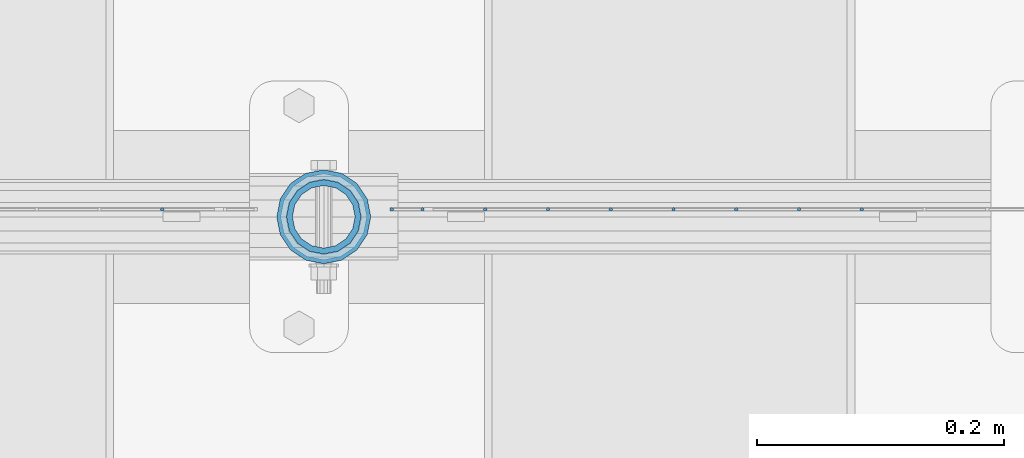
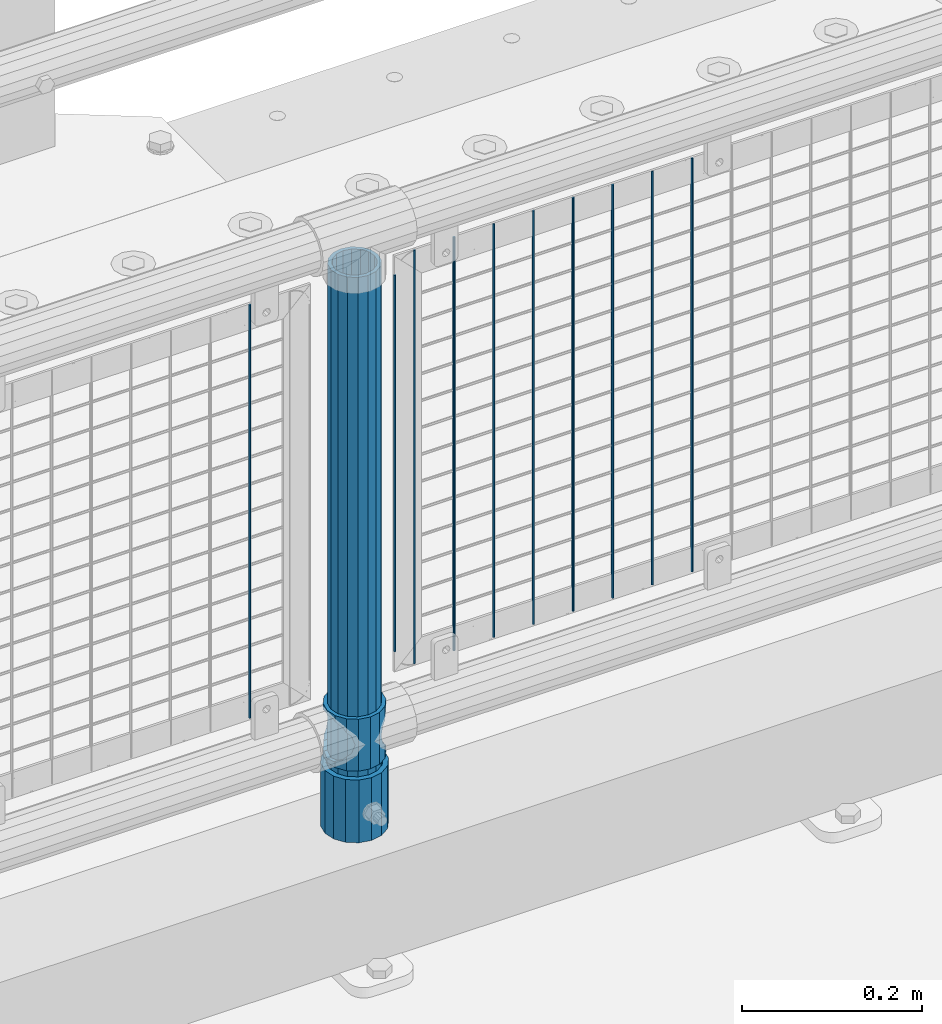
# One storey, part 77 of 270: 13 columns.
"""IFC2X3 building model written with IfcOpenShell, lengths in millimetres."""

import ifcopenshell
import ifcopenshell.guid

model = None  # the IFC model being written
_history = None  # IfcOwnerHistory: only IFC2X3 demands one
_inside = {}  # id of a spatial element -> (the spatial element, [elements in it])
_under = {}  # id of a project, library or spatial element -> (it, [spatial elements below it])
_declared = {}  # id of a project -> (the project, [libraries it declares])
_typed = {}  # id of a type object -> (the type object, [elements of that type])
_made_of = {}  # id of a material, layer set ... -> (it, [elements and type objects made of it])


def new_model(schema):
    """Start an empty IFC model of exactly this schema.

    Asked for "IFC4X3", IfcOpenShell would pick the latest addendum, in which some entities
    have other attributes; the version numbers below select the first issue.
    IFC2X3 requires an IfcOwnerHistory on every rooted entity: one is made here for all.
    """
    global model, _history
    if schema == "IFC4X3":
        model = ifcopenshell.file(schema_version=(4, 3, 0, 0))
    else:
        model = ifcopenshell.file(schema=schema)
    _inside.clear()
    _under.clear()
    _declared.clear()
    _typed.clear()
    _made_of.clear()
    _history = None
    if model.schema == "IFC2X3":
        org = make("IfcOrganization", Name="unknown")
        user = make(
            "IfcPersonAndOrganization",
            ThePerson=make("IfcPerson", FamilyName="unknown"),
            TheOrganization=org,
        )
        app = make(
            "IfcApplication",
            ApplicationDeveloper=org,
            Version="unknown",
            ApplicationFullName="unknown",
            ApplicationIdentifier="unknown",
        )
        _history = make(
            "IfcOwnerHistory",
            OwningUser=user,
            OwningApplication=app,
            ChangeAction="ADDED",
            CreationDate=0,
        )
    return model


def make(cls, **values):
    """One entity of the class cls with the attributes given. An attribute that is None is left unset."""
    return model.create_entity(
        cls, **{name: value for name, value in values.items() if value is not None}
    )


def rooted(cls, **values):
    """An entity with a GlobalId (a new one), such as an element, a storey or a relation."""
    return make(cls, GlobalId=ifcopenshell.guid.new(), OwnerHistory=_history, **values)


def si_unit(unit_type, name, prefix=None):
    """IfcSIUnit, for example si_unit("LENGTHUNIT", "METRE", prefix="MILLI")."""
    return make("IfcSIUnit", UnitType=unit_type, Prefix=prefix, Name=name)


def assignment(units):
    """IfcUnitAssignment: the units of a project."""
    return None if units is None else make("IfcUnitAssignment", Units=units)


def point(xyz):
    """IfcCartesianPoint."""
    return None if xyz is None else make("IfcCartesianPoint", Coordinates=xyz)


def direction(xyz):
    """IfcDirection."""
    return None if xyz is None else make("IfcDirection", DirectionRatios=xyz)


def frame(location, z_axis=None, x_axis=None):
    """IfcAxis2Placement3D, a coordinate frame: its origin and axes. An axis left out is left unset."""
    return make(
        "IfcAxis2Placement3D",
        Location=point(location),
        Axis=direction(z_axis),
        RefDirection=direction(x_axis),
    )


def origin_with_axes():
    """The frame at (0, 0, 0) with the z axis (0, 0, 1) and the x axis (1, 0, 0) written out."""
    return frame((0.0, 0.0, 0.0), z_axis=(0.0, 0.0, 1.0), x_axis=(1.0, 0.0, 0.0))


def place(relative_to, where):
    """IfcLocalPlacement: puts the frame where relative to a parent placement (None: the world)."""
    return make(
        "IfcLocalPlacement", PlacementRelTo=relative_to, RelativePlacement=where
    )


def context(
    kind, dimensions, precision=None, world=None, true_north=None, identifier=None
):
    """IfcGeometricRepresentationContext, for example the 3D "Model" context."""
    return make(
        "IfcGeometricRepresentationContext",
        ContextIdentifier=identifier,
        ContextType=kind,
        CoordinateSpaceDimension=dimensions,
        Precision=precision,
        WorldCoordinateSystem=world,
        TrueNorth=true_north,
    )


def subcontext(parent, identifier, kind, view, scale=None):
    """IfcGeometricRepresentationSubContext, for example "Body" below "Model"."""
    return make(
        "IfcGeometricRepresentationSubContext",
        ContextIdentifier=identifier,
        ContextType=kind,
        ParentContext=parent,
        TargetScale=scale,
        TargetView=view,
    )


def project(units=None, contexts=None):
    """IfcProject with its units and contexts."""
    return rooted(
        "IfcProject",
        Name="project",
        RepresentationContexts=contexts,
        UnitsInContext=assignment(units),
    )


def spatial(cls, under=None, at=None, **own):
    """A site, building, storey or space (cls), placed at a placement, below another one or the project."""
    s = rooted(cls, ObjectPlacement=at, **own)
    if under is not None:
        _under.setdefault(under.id(), (under, []))[1].append(s)
    return s


def faces_of(points, faces, orient=None, outer=None):
    """IfcFace entities. A face is a list of loops; a loop is a list of indices into points, from 0.

    orient and outer hold one flag for each loop. By default every Orientation is true, the
    first loop of a face is its IfcFaceOuterBound and the others are IfcFaceBound.
    """
    made = []
    for i, loops in enumerate(faces):
        bounds = []
        for j, loop in enumerate(loops):
            is_outer = j == 0 if outer is None else outer[i][j]
            bounds.append(
                make(
                    "IfcFaceOuterBound" if is_outer else "IfcFaceBound",
                    Bound=make("IfcPolyLoop", Polygon=[points[k] for k in loop]),
                    Orientation=True if orient is None else orient[i][j],
                )
            )
        made.append(make("IfcFace", Bounds=bounds))
    return made


def faceted_brep(points, faces, orient=None, outer=None, voids=None):
    """IfcFacetedBrep: a solid bounded by flat faces; with voids (closed shells), ...WithVoids."""
    shared = [point(p) for p in points]
    hull = make("IfcClosedShell", CfsFaces=faces_of(shared, faces, orient, outer))
    if voids is None:
        return make("IfcFacetedBrep", Outer=hull)
    return make(
        "IfcFacetedBrepWithVoids",
        Outer=hull,
        Voids=[
            make(cls, CfsFaces=faces_of(shared, fs, o, b)) for cls, fs, o, b in voids
        ],
    )


def shape(context_of_items, identifier, shape_type, items):
    """IfcShapeRepresentation: the items that make up one representation, for example the "Body"."""
    return make(
        "IfcShapeRepresentation",
        ContextOfItems=context_of_items,
        RepresentationIdentifier=identifier,
        RepresentationType=shape_type,
        Items=items,
    )


def material(Name=None, Category=None):
    """IfcMaterial."""
    return make("IfcMaterial", Name=Name, Category=Category)


def made_of(thing, what):
    """Note that an element or type object is made of a material, layer set ...; save() writes the relation."""
    if what is not None:
        _made_of.setdefault(what.id(), (what, []))[1].append(thing)
    return thing


def type_object(cls, material=None, **own):
    """A type object (cls), such as IfcWallType, which elements share."""
    return made_of(rooted(cls, **own), material)


def element(
    cls,
    number,
    at=None,
    inside=None,
    cuts=None,
    type_object=None,
    material=None,
    context=None,
    identifier="Body",
    shape_type=None,
    held_by="IfcProductDefinitionShape",
    body=None,
    shapes=None,
    **own,
):
    """One element of the class cls, such as IfcWall. Its Tag is "e" and its number.

    at: its placement. inside: the storey or other place that contains it. cuts: it is an
    opening in that element (IfcRelVoidsElement). A single representation is given by context,
    identifier, shape_type and body (its items); several are given by shapes. held_by: the class
    of the entity that holds the representations. save() writes the other relations.
    """
    e = rooted(cls, Tag="e%d" % number, ObjectPlacement=at, **own)
    if body is not None:
        shapes = [shape(context, identifier, shape_type, body)]
    if shapes is not None:
        e.Representation = make(held_by, Representations=shapes)
    if inside is not None:
        _inside.setdefault(inside.id(), (inside, []))[1].append(e)
    if cuts is not None:
        rooted(
            "IfcRelVoidsElement", RelatingBuildingElement=cuts, RelatedOpeningElement=e
        )
    if type_object is not None:
        _typed.setdefault(type_object.id(), (type_object, []))[1].append(e)
    return made_of(e, material)


def aggregate(whole, parts):
    """IfcRelAggregates: a whole, such as a stair, and the parts it consists of."""
    return rooted("IfcRelAggregates", RelatingObject=whole, RelatedObjects=parts)


def save(model, path):
    """Write the relations noted so far, then the file.

    IfcRelAggregates (storeys below a building ...), IfcRelContainedInSpatialStructure (elements
    in a storey), IfcRelDefinesByType, IfcRelAssociatesMaterial and IfcRelDeclares: one each for
    every whole, place, type object, material and project.
    """
    for whole, parts in _under.values():
        aggregate(whole, parts)
    for where, things in _inside.values():
        rooted(
            "IfcRelContainedInSpatialStructure",
            RelatedElements=things,
            RelatingStructure=where,
        )
    for kind, things in _typed.values():
        rooted("IfcRelDefinesByType", RelatedObjects=things, RelatingType=kind)
    for what, things in _made_of.values():
        rooted("IfcRelAssociatesMaterial", RelatedObjects=things, RelatingMaterial=what)
    for by, libraries in _declared.values():
        rooted("IfcRelDeclares", RelatingContext=by, RelatedDefinitions=libraries)
    model.write(path)


model = new_model("IFC2X3")

# Units and contexts
model_context = context("Model", 3, precision=1e-05, world=origin_with_axes())
body_context = subcontext(model_context, "Body", "Model", "MODEL_VIEW")
ifc_project = project(units=[si_unit("LENGTHUNIT", "METRE", prefix="MILLI"), si_unit("AREAUNIT", "SQUARE_METRE"), si_unit("VOLUMEUNIT", "CUBIC_METRE"), si_unit("MASSUNIT", "GRAM", prefix="KILO"), si_unit("TIMEUNIT", "SECOND"), si_unit("PLANEANGLEUNIT", "RADIAN"), si_unit("SOLIDANGLEUNIT", "STERADIAN"), si_unit("THERMODYNAMICTEMPERATUREUNIT", "DEGREE_CELSIUS"), si_unit("LUMINOUSINTENSITYUNIT", "LUMEN")], contexts=[model_context])

# Site, building, storey
site_placement = place(None, origin_with_axes())
site = spatial("IfcSite", under=ifc_project, at=site_placement, CompositionType="ELEMENT")
building_placement = place(site_placement, origin_with_axes())
building = spatial("IfcBuilding", under=site, at=building_placement, Name="Standard", CompositionType="ELEMENT")
storey_placement = place(building_placement, origin_with_axes())
storey = spatial("IfcBuildingStorey", under=building, at=storey_placement, Name="Undefined", CompositionType="ELEMENT", Elevation=0.0)

# Columns
ifc_material_1 = material()
column_type_1 = type_object("IfcColumnType", PredefinedType="NOTDEFINED")
column_1_placement = place(storey_placement, frame((5520.0, -16335.5, 168.02), z_axis=(-1.0, 0.0, 0.0), x_axis=(0.0, 0.0, 1.0)))
element("IfcColumn", 1, at=column_1_placement, inside=storey, type_object=column_type_1, material=ifc_material_1, context=body_context, shape_type="Brep", body=[
    faceted_brep([(0.0, -25.3500000000004, 0.0), (0.0, -23.4203461491616, 9.70102501045403), (760.0, -23.4203461491616, 9.70102501045403), (760.0, -25.3500000000004, 0.0), (0.0, -17.9251569030785, 17.9251569030785), (760.0, -17.9251569030785, 17.9251569030785), (0.0, -9.70102501045585, 23.4203461491597), (760.0, -9.70102501045585, 23.4203461491597), (0.0, 0.0, 25.3499999999985), (760.0, 0.0, 25.3499999999985), (0.0, 9.70102501045585, 23.4203461491597), (760.0, 9.70102501045585, 23.4203461491597), (0.0, 17.9251569030785, 17.9251569030785), (760.0, 17.9251569030785, 17.9251569030785), (0.0, 23.4203461491616, 9.70102501045403), (760.0, 23.4203461491616, 9.70102501045403), (0.0, 25.3500000000004, 0.0), (760.0, 25.3500000000004, 0.0), (0.0, 23.4203461491616, -9.70102501045403), (760.0, 23.4203461491616, -9.70102501045403), (0.0, 17.9251569030785, -17.9251569030785), (760.0, 17.9251569030785, -17.9251569030785), (0.0, 9.70102501045585, -23.4203461491597), (760.0, 9.70102501045585, -23.4203461491597), (0.0, 0.0, -25.3499999999985), (760.0, 0.0, -25.3499999999985), (0.0, -9.70102501045585, -23.4203461491597), (760.0, -9.70102501045585, -23.4203461491597), (0.0, -17.9251569030785, -17.9251569030785), (760.0, -17.9251569030785, -17.9251569030785), (0.0, -23.4203461491616, -9.70102501045403), (760.0, -23.4203461491616, -9.70102501045403), (0.0, -30.1499999999996, 0.0), (0.0, -27.8549679052157, -11.5379054858058), (760.0, -27.8549679052157, -11.5379054858058), (760.0, -30.1499999999996, 0.0), (0.0, -21.3192694527752, -21.3192694527752), (760.0, -21.3192694527752, -21.3192694527752), (0.0, -11.5379054858076, -27.8549679052157), (760.0, -11.5379054858076, -27.8549679052157), (0.0, 0.0, -30.1500000000015), (760.0, 0.0, -30.1500000000015), (0.0, 11.5379054858076, -27.8549679052157), (760.0, 11.5379054858076, -27.8549679052157), (0.0, 21.3192694527752, -21.3192694527752), (760.0, 21.3192694527752, -21.3192694527752), (0.0, 27.8549679052157, -11.5379054858058), (760.0, 27.8549679052157, -11.5379054858058), (0.0, 30.1499999999996, 0.0), (760.0, 30.1499999999996, 0.0), (0.0, 27.8549679052157, 11.5379054858058), (760.0, 27.8549679052157, 11.5379054858058), (0.0, 21.3192694527752, 21.3192694527752), (760.0, 21.3192694527752, 21.3192694527752), (0.0, 11.5379054858076, 27.8549679052157), (760.0, 11.5379054858076, 27.8549679052157), (0.0, 0.0, 30.1500000000015), (760.0, 0.0, 30.1500000000015), (0.0, -11.5379054858076, 27.8549679052157), (760.0, -11.5379054858076, 27.8549679052157), (0.0, -21.3192694527752, 21.3192694527752), (760.0, -21.3192694527752, 21.3192694527752), (0.0, -27.8549679052157, 11.5379054858058), (760.0, -27.8549679052157, 11.5379054858058)], [[[0, 1, 2, 3]], [[1, 4, 5, 2]], [[4, 6, 7, 5]], [[6, 8, 9, 7]], [[8, 10, 11, 9]], [[10, 12, 13, 11]], [[12, 14, 15, 13]], [[14, 16, 17, 15]], [[16, 18, 19, 17]], [[18, 20, 21, 19]], [[20, 22, 23, 21]], [[22, 24, 25, 23]], [[24, 26, 27, 25]], [[26, 28, 29, 27]], [[28, 30, 31, 29]], [[30, 0, 3, 31]], [[32, 33, 34, 35]], [[33, 36, 37, 34]], [[36, 38, 39, 37]], [[38, 40, 41, 39]], [[40, 42, 43, 41]], [[42, 44, 45, 43]], [[44, 46, 47, 45]], [[46, 48, 49, 47]], [[48, 50, 51, 49]], [[50, 52, 53, 51]], [[52, 54, 55, 53]], [[54, 56, 57, 55]], [[56, 58, 59, 57]], [[58, 60, 61, 59]], [[60, 62, 63, 61]], [[62, 32, 35, 63]], [[37, 39, 41, 43, 45, 47, 49, 51, 53, 55, 57, 59, 61, 63, 35, 34], [5, 7, 9, 11, 13, 15, 17, 19, 21, 23, 25, 27, 29, 31, 3, 2]], [[62, 60, 58, 56, 54, 52, 50, 48, 46, 44, 42, 40, 38, 36, 33, 32], [30, 28, 26, 24, 22, 20, 18, 16, 14, 12, 10, 8, 6, 4, 1, 0]]]),
])
column_type_2 = type_object("IfcColumnType", PredefinedType="NOTDEFINED")
column_2_placement = place(storey_placement, frame((5520.0, -16335.5, 168.02), z_axis=(0.0, 1.0, 0.0), x_axis=(0.0, 0.0, 1.0)))
element("IfcColumn", 2, at=column_2_placement, inside=storey, type_object=column_type_2, material=ifc_material_1, context=body_context, shape_type="Brep", body=[
    faceted_brep([(0.0, -31.75, 0.0), (0.0, -29.3331751572332, 12.1501989775916), (85.0, -29.3331751572332, 12.1501989775916), (85.0, -31.75, 0.0), (0.0, -22.4506403026717, 22.4506403026735), (85.0, -22.4506403026717, 22.4506403026735), (0.0, -12.1501989775934, 29.3331751572332), (85.0, -12.1501989775934, 29.3331751572332), (0.0, 0.0, 31.75), (85.0, 0.0, 31.75), (0.0, 12.1501989775934, 29.3331751572332), (85.0, 12.1501989775934, 29.3331751572332), (0.0, 22.4506403026717, 22.4506403026735), (85.0, 22.4506403026717, 22.4506403026735), (0.0, 29.3331751572332, 12.1501989775916), (85.0, 29.3331751572332, 12.1501989775916), (0.0, 31.75, 0.0), (85.0, 31.75, 0.0), (0.0, 29.3331751572332, -12.1501989775916), (85.0, 29.3331751572332, -12.1501989775916), (0.0, 22.4506403026717, -22.4506403026735), (85.0, 22.4506403026717, -22.4506403026735), (0.0, 12.1501989775934, -29.3331751572332), (85.0, 12.1501989775934, -29.3331751572332), (0.0, 0.0, -31.75), (85.0, 0.0, -31.75), (0.0, -12.1501989775934, -29.3331751572332), (85.0, -12.1501989775934, -29.3331751572332), (0.0, -22.4506403026717, -22.4506403026735), (85.0, -22.4506403026717, -22.4506403026735), (0.0, -29.3331751572332, -12.1501989775916), (85.0, -29.3331751572332, -12.1501989775916), (0.0, -38.0499999999993, 0.0), (0.0, -35.1536162120537, -14.561104601491), (85.0, -35.1536162120537, -14.561104601491), (85.0, -38.0499999999993, 0.0), (0.0, -26.9054130241493, -26.9054130241475), (85.0, -26.9054130241493, -26.9054130241475), (0.0, -14.5611046014928, -35.1536162120537), (85.0, -14.5611046014928, -35.1536162120537), (0.0, 0.0, -38.0499999999993), (85.0, 0.0, -38.0499999999993), (0.0, 14.5611046014928, -35.1536162120537), (85.0, 14.5611046014928, -35.1536162120537), (0.0, 26.9054130241493, -26.9054130241475), (85.0, 26.9054130241493, -26.9054130241475), (0.0, 35.1536162120537, -14.561104601491), (85.0, 35.1536162120537, -14.561104601491), (0.0, 38.0499999999993, 0.0), (85.0, 38.0499999999993, 0.0), (0.0, 35.1536162120537, 14.561104601491), (85.0, 35.1536162120537, 14.561104601491), (0.0, 26.9054130241493, 26.9054130241475), (85.0, 26.9054130241493, 26.9054130241475), (0.0, 14.5611046014928, 35.1536162120537), (85.0, 14.5611046014928, 35.1536162120537), (0.0, 0.0, 38.0499999999993), (85.0, 0.0, 38.0499999999993), (0.0, -14.5611046014928, 35.1536162120537), (85.0, -14.5611046014928, 35.1536162120537), (0.0, -26.9054130241493, 26.9054130241475), (85.0, -26.9054130241493, 26.9054130241475), (0.0, -35.1536162120537, 14.561104601491), (85.0, -35.1536162120537, 14.561104601491)], [[[0, 1, 2, 3]], [[1, 4, 5, 2]], [[4, 6, 7, 5]], [[6, 8, 9, 7]], [[8, 10, 11, 9]], [[10, 12, 13, 11]], [[12, 14, 15, 13]], [[14, 16, 17, 15]], [[16, 18, 19, 17]], [[18, 20, 21, 19]], [[20, 22, 23, 21]], [[22, 24, 25, 23]], [[24, 26, 27, 25]], [[26, 28, 29, 27]], [[28, 30, 31, 29]], [[30, 0, 3, 31]], [[32, 33, 34, 35]], [[33, 36, 37, 34]], [[36, 38, 39, 37]], [[38, 40, 41, 39]], [[40, 42, 43, 41]], [[42, 44, 45, 43]], [[44, 46, 47, 45]], [[46, 48, 49, 47]], [[48, 50, 51, 49]], [[50, 52, 53, 51]], [[52, 54, 55, 53]], [[54, 56, 57, 55]], [[56, 58, 59, 57]], [[58, 60, 61, 59]], [[60, 62, 63, 61]], [[62, 32, 35, 63]], [[37, 39, 41, 43, 45, 47, 49, 51, 53, 55, 57, 59, 61, 63, 35, 34], [5, 7, 9, 11, 13, 15, 17, 19, 21, 23, 25, 27, 29, 31, 3, 2]], [[62, 60, 58, 56, 54, 52, 50, 48, 46, 44, 42, 40, 38, 36, 33, 32], [30, 28, 26, 24, 22, 20, 18, 16, 14, 12, 10, 8, 6, 4, 1, 0]]]),
])
ifc_material_2 = material(Name="Misc_Undefined")
column_type_3 = type_object("IfcColumnType", PredefinedType="NOTDEFINED")
column_3_placement = place(storey_placement, frame((5520.0, -16335.5, 263.02), z_axis=(-1.0, 0.0, 0.0), x_axis=(0.0, 0.0, 1.0)))
element("IfcColumn", 3, at=column_3_placement, inside=storey, type_object=column_type_3, material=ifc_material_2, context=body_context, shape_type="Brep", body=[
    faceted_brep([(63.1897438117183, 11.6144421722802, -32.8397438117208), (63.1897438117183, 11.6144421722802, -28.0397438117179), (56.6106908090125, 21.4606908090118, -21.46069080901), (56.6106908090125, 21.4606908090118, -27.1226768591005), (61.9623795176767, 13.4513226476338, -32.4743655677703), (46.7644421722812, 28.0397438117179, -11.614442172282), (46.7644421722812, 28.0397438117179, -20.0882031229812), (51.5310424080071, 24.8548033587067, -24.8548033587067), (35.1500000000015, 30.35, 0.0), (35.1500000000008, 30.3500000000004, -16.6306603983612), (23.5355578277203, 28.0397438117179, -11.614442172282), (23.5355578277203, 28.0397438117179, -20.0882031229812), (18.7689575919954, 24.8548033587067, -24.8548033587067), (13.689309190989, 21.4606908090118, -21.46069080901), (13.689309190989, 21.4606908090118, -27.1226768591005), (8.33762048232484, 13.4513226476338, -32.4743655677703), (7.11025618828324, 11.6144421722802, -28.0397438117179), (7.11025618828324, 11.6144421722802, -32.8397438117208), (4.80000000000075, 0.0, -30.3499999999985), (4.80000000000075, 0.0, -35.1500000000015), (7.11025618828319, -11.6144421722802, -28.0397438117179), (7.11025618828319, -11.6144421722802, -32.8397438117172), (13.689309190989, -21.4606908090118, -21.46069080901), (13.689309190989, -21.4606908090118, -27.1226768591041), (8.33762048232484, -13.4513226476338, -32.4743655677703), (23.5355578277203, -28.0397438117179, -11.614442172282), (23.5355578277203, -28.0397438117179, -20.0882031229885), (18.7689575919954, -24.8548033587067, -24.8548033587067), (35.1500000000015, -30.35, 0.0), (35.1500000000008, -30.3500000000004, -16.6306603983721), (46.7644421722812, -28.0397438117179, -11.614442172282), (46.7644421722812, -28.0397438117179, -20.0882031229885), (51.5310424080071, -24.8548033587067, -24.8548033587067), (56.6106908090125, -21.4606908090118, -21.46069080901), (56.6106908090125, -21.4606908090118, -27.1226768591041), (61.9623795176767, -13.4513226476338, -32.4743655677703), (63.1897438117183, -11.6144421722802, -28.0397438117179), (63.1897438117183, -11.6144421722802, -32.8397438117172), (65.5000000000008, 0.0, -30.3499999999985), (65.5000000000008, 0.0, -35.1500000000015), (0.0, -28.0397438117179, -11.614442172282), (0.0, -30.3500000000004, 0.0), (0.0, -21.4606908090118, -21.46069080901), (0.0, -11.6144421722802, -28.0397438117179), (0.0, 0.0, -30.3499999999985), (0.0, 11.6144421722802, -28.0397438117179), (0.0, 21.4606908090118, -21.46069080901), (0.0, 28.0397438117179, -11.614442172282), (0.0, 30.3500000000004, 0.0), (0.0, 28.0397438117179, 11.614442172282), (23.5355578277192, 28.0397438117179, 11.614442172282), (0.0, 21.4606908090118, 21.46069080901), (13.6893091909879, 21.4606908090118, 21.46069080901), (0.0, 11.6144421722802, 28.0397438117179), (7.11025618828211, 11.6144421722802, 28.0397438117179), (0.0, 0.0, 30.3499999999985), (4.79999999999961, 0.0, 30.3499999999985), (0.0, -11.6144421722802, 28.0397438117179), (7.11025618828205, -11.6144421722802, 28.0397438117179), (0.0, -21.4606908090118, 21.46069080901), (13.6893091909879, -21.4606908090118, 21.46069080901), (0.0, -28.0397438117179, 11.614442172282), (23.5355578277191, -28.0397438117179, 11.614442172282), (0.0, -32.4743655677721, 13.4513226476338), (0.0, -35.1499999999996, 0.0), (70.2999999999993, -35.1499999999996, 0.0), (70.2999999999993, -32.4743655677721, 13.4513226476338), (0.0, 13.4513226476338, -32.4743655677703), (0.0, 24.8548033587067, -24.8548033587067), (0.0, 0.0, -35.1499999999996), (0.0, -13.4513226476338, -32.4743655677703), (0.0, -24.8548033587067, -24.8548033587067), (0.0, -24.8548033587067, 24.8548033587067), (0.0, -13.4513226476338, 32.4743655677703), (0.0, 0.0, 35.1499999999996), (0.0, 13.4513226476338, 32.4743655677703), (0.0, 24.8548033587067, 24.8548033587067), (0.0, 32.4743655677721, 13.4513226476338), (0.0, 35.1499999999996, 0.0), (0.0, 32.4743655677721, -13.4513226476338), (0.0, -32.4743655677721, -13.4513226476338), (70.2999999999993, 32.4743655677721, 13.4513226476338), (70.2999999999993, 35.1499999999996, 0.0), (70.2999999999993, 32.4743655677721, -13.4513226476338), (70.2999999999993, 24.8548033587067, -24.8548033587067), (70.2999999999993, 13.4513226476338, -32.4743655677703), (70.2999999999993, 0.0, -35.1500000000015), (70.2999999999993, -13.4513226476338, -32.4743655677703), (70.2999999999993, -24.8548033587067, -24.8548033587067), (70.2999999999993, -32.4743655677721, -13.4513226476338), (70.2999999999993, 28.0397438117179, 11.614442172282), (70.2999999999993, 21.4606908090118, 21.46069080901), (56.6106908090114, 21.4606908090118, 21.46069080901), (46.7644421722801, 28.0397438117179, 11.614442172282), (70.2999999999993, 11.6144421722802, 28.0397438117179), (63.1897438117172, 11.6144421722802, 28.0397438117179), (70.2999999999993, 0.0, 30.3499999999985), (65.4999999999997, 0.0, 30.3499999999985), (70.2999999999993, -11.6144421722802, 28.0397438117179), (63.1897438117172, -11.6144421722802, 28.0397438117179), (70.2999999999993, -21.4606908090118, 21.46069080901), (56.6106908090114, -21.4606908090118, 21.46069080901), (70.2999999999993, -28.0397438117179, 11.614442172282), (46.7644421722801, -28.0397438117179, 11.614442172282), (70.2999999999993, -11.6144421722802, -28.0397438117179), (70.2999999999993, 0.0, -30.3499999999985), (70.2999999999993, -21.4606908090118, -21.46069080901), (70.2999999999993, -28.0397438117179, -11.614442172282), (70.2999999999993, -30.3500000000004, 0.0), (70.2999999999993, 24.8548033587067, 24.8548033587067), (70.2999999999993, 13.4513226476338, 32.4743655677703), (70.2999999999993, 0.0, 35.1500000000015), (70.2999999999993, -13.4513226476338, 32.4743655677703), (70.2999999999993, -24.8548033587067, 24.8548033587067), (70.2999999999993, 30.3500000000004, 0.0), (70.2999999999993, 28.0397438117179, -11.614442172282), (70.2999999999993, 21.4606908090118, -21.46069080901), (70.2999999999993, 11.6144421722802, -28.0397438117179), (61.9623795176767, 13.4513226476338, 32.4743655677703), (51.5310424080039, 24.8548033587067, 24.8548033587067), (56.6106908090114, 21.4606908090118, 27.1226768591041), (65.4999999999997, 0.0, 35.1500000000015), (63.1897438117172, 11.6144421722802, 32.8397438117172), (63.1897438117172, -11.6144421722802, 32.8397438117172), (61.9623795176767, -13.4513226476338, 32.4743655677703), (56.6106908090114, -21.4606908090118, 27.1226768591077), (51.5310424080071, -24.8548033587067, 24.8548033587067), (18.7689575919954, -24.8548033587067, 24.8548033587067), (46.7644421722801, -28.0397438117179, 20.0882031229849), (35.1499999999996, -30.3500000000004, 16.6306603983649), (23.5355578277191, -28.0397438117179, 20.0882031229849), (8.33762048232262, -13.4513226476338, 32.4743655677703), (13.6893091909879, -21.4606908090118, 27.1226768591077), (4.79999999999961, 0.0, 35.1500000000015), (7.11025618828205, -11.6144421722802, 32.8397438117172), (7.11025618828211, 11.6144421722802, 32.8397438117172), (8.33762048232262, 13.4513226476338, 32.4743655677703), (13.6893091909879, 21.4606908090118, 27.1226768591041), (18.7689575919954, 24.8548033587067, 24.8548033587067), (23.5355578277192, 28.0397438117179, 20.0882031229885), (35.1499999999996, 30.3500000000004, 16.6306603983685), (46.7644421722801, 28.0397438117179, 20.0882031229885)], [[[0, 1, 2, 3, 4]], [[3, 2, 5, 6, 7]], [[6, 5, 8, 9]], [[9, 8, 10, 11]], [[12, 11, 10, 13, 14]], [[15, 14, 13, 16, 17]], [[17, 16, 18, 19]], [[19, 18, 20, 21]], [[21, 20, 22, 23, 24]], [[23, 22, 25, 26, 27]], [[26, 25, 28, 29]], [[29, 28, 30, 31]], [[32, 31, 30, 33, 34]], [[35, 34, 33, 36, 37]], [[37, 36, 38, 39]], [[39, 38, 1, 0]], [[40, 41, 28, 25]], [[42, 40, 25, 22]], [[43, 42, 22, 20]], [[44, 43, 20, 18]], [[45, 44, 18, 16]], [[46, 45, 16, 13]], [[47, 46, 13, 10]], [[48, 47, 10, 8]], [[49, 48, 8, 50]], [[51, 49, 50, 52]], [[53, 51, 52, 54]], [[55, 53, 54, 56]], [[57, 55, 56, 58]], [[59, 57, 58, 60]], [[61, 59, 60, 62]], [[41, 61, 62, 28]], [[63, 64, 65, 66]], [[67, 68, 12, 14, 15]], [[69, 67, 15, 17, 19]], [[24, 70, 69, 19, 21]], [[27, 71, 70, 24, 23]], [[63, 72, 73, 74, 75, 76, 77, 78, 79, 68, 67, 69, 70, 71, 80, 64], [40, 42, 43, 44, 45, 46, 47, 48, 49, 51, 53, 55, 57, 59, 61, 41]], [[78, 77, 81, 82]], [[79, 78, 82, 83]], [[68, 79, 83, 84, 7, 6, 9, 11, 12]], [[7, 84, 85, 4, 3]], [[4, 85, 86, 39, 0]], [[87, 88, 32, 34, 35]], [[86, 87, 35, 37, 39]], [[29, 31, 32, 88, 89, 80, 71, 27, 26]], [[64, 80, 89, 65]], [[90, 91, 92, 93]], [[91, 94, 95, 92]], [[94, 96, 97, 95]], [[96, 98, 99, 97]], [[98, 100, 101, 99]], [[100, 102, 103, 101]], [[104, 105, 38, 36]], [[106, 104, 36, 33]], [[107, 106, 33, 30]], [[108, 107, 30, 28]], [[102, 108, 28, 103]], [[88, 87, 86, 85, 84, 83, 82, 81, 109, 110, 111, 112, 113, 66, 65, 89], [100, 98, 96, 94, 91, 90, 114, 115, 116, 117, 105, 104, 106, 107, 108, 102]], [[118, 110, 109, 119, 120]], [[121, 111, 110, 118, 122]], [[112, 111, 121, 123, 124]], [[113, 112, 124, 125, 126]], [[127, 72, 63, 66, 113, 126, 128, 129, 130]], [[131, 73, 72, 127, 132]], [[133, 74, 73, 131, 134]], [[75, 74, 133, 135, 136]], [[76, 75, 136, 137, 138]], [[119, 109, 81, 77, 76, 138, 139, 140, 141]], [[92, 120, 119, 141, 93]], [[95, 122, 118, 120, 92]], [[97, 121, 122, 95]], [[99, 123, 121, 97]], [[101, 125, 124, 123, 99]], [[103, 128, 126, 125, 101]], [[28, 129, 128, 103]], [[62, 130, 129, 28]], [[60, 132, 127, 130, 62]], [[58, 134, 131, 132, 60]], [[56, 133, 134, 58]], [[54, 135, 133, 56]], [[52, 137, 136, 135, 54]], [[50, 139, 138, 137, 52]], [[8, 140, 139, 50]], [[93, 141, 140, 8]], [[114, 90, 93, 8]], [[115, 114, 8, 5]], [[116, 115, 5, 2]], [[117, 116, 2, 1]], [[105, 117, 1, 38]]]),
])
column_type_4 = type_object("IfcColumnType", Name="D3", PredefinedType="NOTDEFINED")
for number, where, z_axis, x_axis in (
    (4, (5955.551, -16329.5, 353.02), (-1.0, 0.0, 0.0), (0.0, 0.0, 1.0)),
    (5, (5904.758, -16329.5, 353.02), (-1.0, 0.0, 0.0), (0.0, 0.0, 1.0)),
    (6, (5853.965, -16329.5, 353.02), (-1.0, 0.0, 0.0), (0.0, 0.0, 1.0)),
    (7, (5803.172, -16329.5, 353.02), (-1.0, 0.0, 0.0), (0.0, 0.0, 1.0)),
    (8, (5752.379, -16329.5, 353.02), (-1.0, 0.0, 0.0), (0.0, 0.0, 1.0)),
    (9, (5701.586, -16329.5, 353.02), (-1.0, 0.0, 0.0), (0.0, 0.0, 1.0)),
    (10, (5650.793, -16329.5, 353.02), (-1.0, 0.0, 0.0), (0.0, 0.0, 1.0)),
):
    element("IfcColumn", number, at=place(storey_placement, frame(where, z_axis=z_axis, x_axis=x_axis)), inside=storey, type_object=column_type_4, material=ifc_material_2, ObjectType="D3", context=body_context, shape_type="Brep", body=[
        faceted_brep([(0.0, -1.5, 0.0), (0.0, -0.75, -1.29903810567669), (560.0, -0.75, -1.29903810567703), (560.0, -1.5, 0.0), (0.0, 0.75, -1.29903810567669), (560.0, 0.75, -1.29903810567703), (0.0, 1.5, 0.0), (560.0, 1.5, 0.0), (0.0, 0.75, 1.29903810567669), (560.0, 0.75, 1.29903810567703), (0.0, -0.75, 1.29903810567669), (560.0, -0.75, 1.29903810567703)], [[[0, 1, 2, 3]], [[1, 4, 5, 2]], [[4, 6, 7, 5]], [[6, 8, 9, 7]], [[8, 10, 11, 9]], [[10, 0, 3, 11]], [[5, 7, 9, 11, 3, 2]], [[10, 8, 6, 4, 1, 0]]]),
    ])
column_4_placement = place(storey_placement, frame((5575.0, -16329.5, 378.02), z_axis=(-1.0, 0.0, 0.0), x_axis=(0.0, 0.0, 1.0)))
element("IfcColumn", 11, at=column_4_placement, inside=storey, type_object=column_type_4, material=ifc_material_2, ObjectType="D3", context=body_context, shape_type="Brep", body=[
    faceted_brep([(0.0, -1.5, 0.0), (0.0, -0.75, -1.29903810567669), (510.0, -0.75, -1.29903810567703), (510.0, -1.5, 0.0), (0.0, 0.75, -1.29903810567669), (510.0, 0.75, -1.29903810567703), (0.0, 1.5, 0.0), (510.0, 1.5, 0.0), (0.0, 0.75, 1.29903810567669), (510.0, 0.75, 1.29903810567703), (0.0, -0.75, 1.29903810567669), (510.0, -0.75, 1.29903810567703)], [[[0, 1, 2, 3]], [[1, 4, 5, 2]], [[4, 6, 7, 5]], [[6, 8, 9, 7]], [[8, 10, 11, 9]], [[10, 0, 3, 11]], [[5, 7, 9, 11, 3, 2]], [[10, 8, 6, 4, 1, 0]]]),
])
for number, where, z_axis, x_axis in (
    (12, (5600.0, -16329.5, 353.02), (-1.0, 0.0, 0.0), (0.0, 0.0, 1.0)),
    (13, (5389.204, -16329.5, 353.02), (-1.0, 0.0, 0.0), (0.0, 0.0, 1.0)),
):
    element("IfcColumn", number, at=place(storey_placement, frame(where, z_axis=z_axis, x_axis=x_axis)), inside=storey, type_object=column_type_4, material=ifc_material_2, ObjectType="D3", context=body_context, shape_type="Brep", body=[
        faceted_brep([(0.0, -1.5, 0.0), (0.0, -0.75, -1.29903810567669), (560.0, -0.75, -1.29903810567703), (560.0, -1.5, 0.0), (0.0, 0.75, -1.29903810567669), (560.0, 0.75, -1.29903810567703), (0.0, 1.5, 0.0), (560.0, 1.5, 0.0), (0.0, 0.75, 1.29903810567669), (560.0, 0.75, 1.29903810567703), (0.0, -0.75, 1.29903810567669), (560.0, -0.75, 1.29903810567703)], [[[0, 1, 2, 3]], [[1, 4, 5, 2]], [[4, 6, 7, 5]], [[6, 8, 9, 7]], [[8, 10, 11, 9]], [[10, 0, 3, 11]], [[5, 7, 9, 11, 3, 2]], [[10, 8, 6, 4, 1, 0]]]),
    ])

save(model, "model.ifc")
